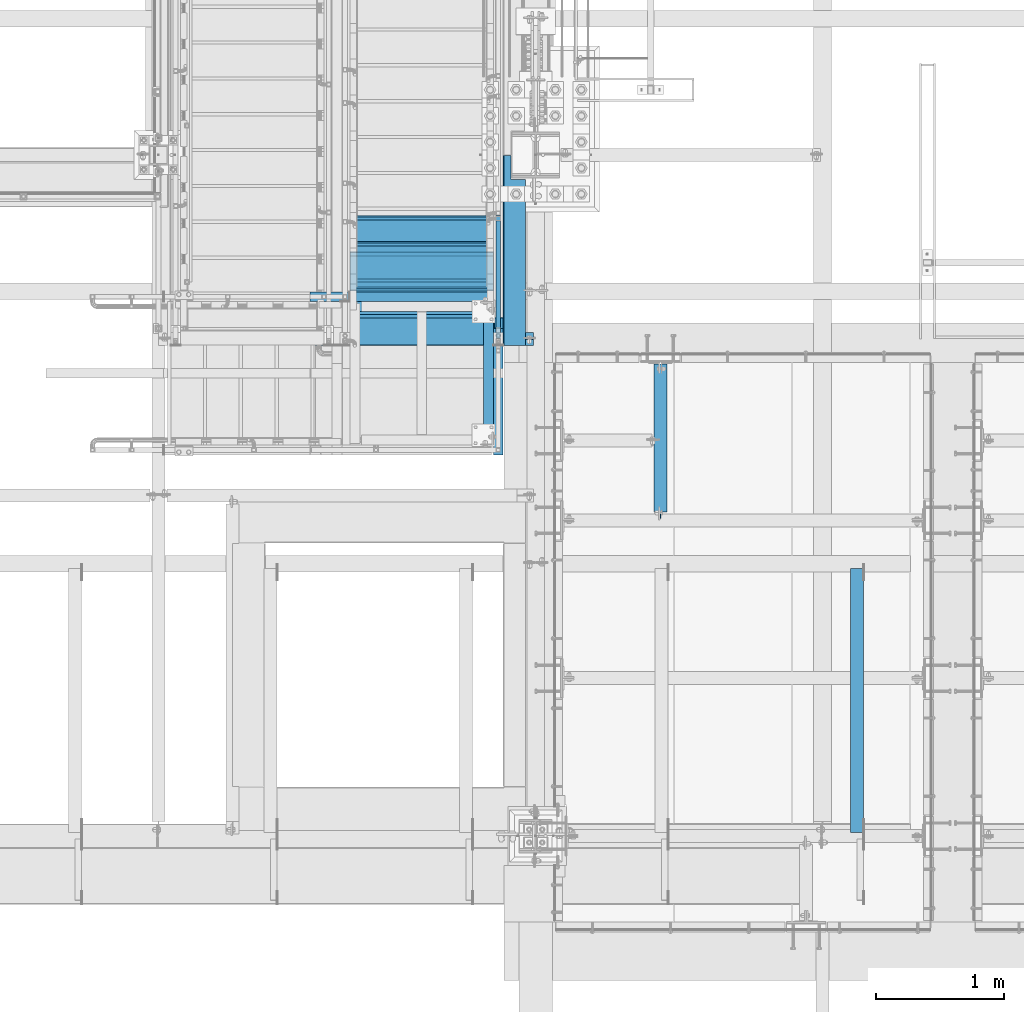
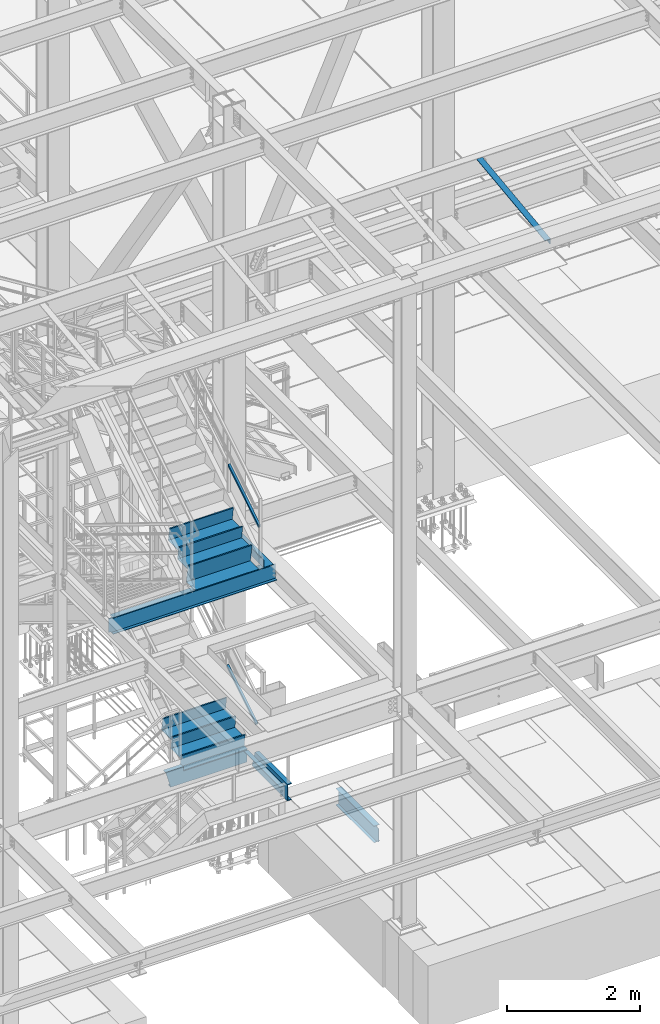
# One storey, part 1762 of 3843: 14 beams, 2 members, 9 elements without a shape of their own.
"""IFC2X3 building model written with IfcOpenShell, lengths in millimetres."""

from ifc_helpers import new_model, si_unit, frame, origin_with_axes, place, context, subcontext, project, spatial, faceted_brep, material, type_object, element, aggregate, save


model = new_model("IFC2X3")

# Units and contexts
model_context = context("Model", 3, precision=1e-05, world=origin_with_axes())
body_context = subcontext(model_context, "Body", "Model", "MODEL_VIEW")
ifc_project = project(units=[si_unit("LENGTHUNIT", "METRE", prefix="MILLI"), si_unit("AREAUNIT", "SQUARE_METRE"), si_unit("VOLUMEUNIT", "CUBIC_METRE"), si_unit("MASSUNIT", "GRAM", prefix="KILO"), si_unit("TIMEUNIT", "SECOND"), si_unit("PLANEANGLEUNIT", "RADIAN"), si_unit("SOLIDANGLEUNIT", "STERADIAN"), si_unit("THERMODYNAMICTEMPERATUREUNIT", "DEGREE_CELSIUS"), si_unit("LUMINOUSINTENSITYUNIT", "LUMEN")], contexts=[model_context])

# Site, building, storey
site_placement = place(None, origin_with_axes())
site = spatial("IfcSite", under=ifc_project, at=site_placement, CompositionType="ELEMENT")
building_placement = place(site_placement, origin_with_axes())
building = spatial("IfcBuilding", under=site, at=building_placement, Name="Undefined", CompositionType="ELEMENT")
storey_placement = place(building_placement, origin_with_axes())
storey = spatial("IfcBuildingStorey", under=building, at=storey_placement, Name="Undefined", CompositionType="ELEMENT", Elevation=0.0)

# Assembly, member
assembly_1_placement = place(storey_placement, origin_with_axes())
assembly_1 = element("IfcElementAssembly", 1, at=assembly_1_placement, inside=storey, Name="RAIL", AssemblyPlace="NOTDEFINED", PredefinedType="RIGID_FRAME")
ifc_material_1 = material()
member_type = type_object("IfcMemberType", Name="HSS1-1/2X1-1/2X1/4", PredefinedType="NOTDEFINED")
member_1_placement = place(assembly_1_placement, frame((55638.6999999992, 18859.5000000038, 35547.2230284887), z_axis=(0.0, -0.529536736899111, 0.848287005838379), x_axis=(0.0, 0.848287005838377, 0.529536736899114)))
member_1 = element("IfcMember", 2, at=member_1_placement, type_object=member_type, material=ifc_material_1, Name="RAIL", ObjectType="HSS1-1/2X1-1/2X1/4", context=body_context, shape_type="Brep", body=[
    faceted_brep([(1112.28589844752, -19.0499992350015, 19.0499992315272), (1088.50226304266, -19.0499992350015, -19.0499992383411), (1088.50226304266, 19.0499992350015, -19.0499992383411), (1112.28589844752, 19.0499992350015, 19.0499992315272), (1108.32195911351, -12.6999993299978, 12.699999326549), (1108.32195911351, 12.6999993299978, 12.699999326549), (1092.46620237669, 12.6999993299978, -12.6999993333629), (1092.46620237669, -12.6999993299978, -12.6999993333629), (34.3488397583606, 19.0499992350015, 19.0499992348923), (34.3488397583606, -19.0499999999956, 19.0499992348923), (10.5652043534537, -19.0499992350015, -19.0499992349432), (10.5652043534537, 19.0499992350015, -19.0499992349432), (30.3849004243275, -12.6999993300014, 12.6999993299178), (14.5291436874832, -12.6999993300014, -12.6999993299687), (14.5291436874832, 12.6999993300014, -12.6999993299687), (30.3849004243275, 12.6999993300014, 12.6999993299178)], [[[0, 1, 2, 3], [4, 5, 6, 7]], [[0, 3, 8, 9]], [[2, 1, 10, 11]], [[1, 0, 9, 10]], [[3, 2, 11, 8]], [[9, 8, 11, 10], [12, 13, 14, 15]], [[4, 7, 13, 12]], [[7, 6, 14, 13]], [[6, 5, 15, 14]], [[5, 4, 12, 15]]]),
])
aggregate(assembly_1, [member_1])

assembly_2_placement = place(storey_placement, origin_with_axes())
assembly_2 = element("IfcElementAssembly", 3, at=assembly_2_placement, inside=storey, Name="RAIL", AssemblyPlace="NOTDEFINED", PredefinedType="RIGID_FRAME")
member_2_placement = place(assembly_2_placement, frame((55638.7000000026, 18961.0999978671, 31873.0923071052), z_axis=(0.0, -0.524097425050603, 0.851658317082225), x_axis=(0.0, 0.851658317082228, 0.524097425050598)))
member_2 = element("IfcMember", 4, at=member_2_placement, type_object=member_type, material=ifc_material_1, Name="RAIL", ObjectType="HSS1-1/2X1-1/2X1/4", context=body_context, shape_type="Brep", body=[
    faceted_brep([(-3.59463567009516, 12.6999993300014, -12.6999993299978), (-3.59463567009516, -12.6999993300014, -12.6999993299978), (1017.39036485115, -12.6999993299978, -12.6999993288809), (1017.39036485115, 12.6999993299978, -12.6999993288809), (3.59463559381402, -12.6999993300014, 12.6999993299833), (1033.02113323208, -12.6999993299978, 12.6999993311583), (3.59463559381402, 12.6999993300014, 12.6999993299833), (1033.02113323208, 12.6999993299978, 12.6999993311583), (-5.39195355401171, 19.0499992350015, -19.0499992349942), (5.39195347770146, 19.0499992350015, 19.0499992349796), (1036.92882547501, 19.0499992350015, 19.049999236162), (1013.48267260822, 19.0499992350015, -19.0499992338882), (5.39195347770146, -19.0499992350015, 19.0499992349796), (1036.92882547501, -19.0499992350015, 19.049999236162), (-5.39195355401171, -19.0499992350015, -19.0499992349942), (1013.48267260822, -19.0499992350015, -19.0499992338882)], [[[0, 1, 2, 3]], [[1, 4, 5, 2]], [[4, 6, 7, 5]], [[6, 0, 3, 7]], [[8, 9, 10, 11]], [[9, 12, 13, 10]], [[12, 14, 15, 13]], [[14, 8, 11, 15]], [[13, 15, 11, 10], [5, 7, 3, 2]], [[14, 12, 9, 8], [6, 4, 1, 0]]]),
])
aggregate(assembly_2, [member_2])

# Assembly, beam
assembly_3_placement = place(storey_placement, origin_with_axes())
assembly_3 = element("IfcElementAssembly", 5, at=assembly_3_placement, inside=storey, Name="STAIR", AssemblyPlace="NOTDEFINED", PredefinedType="RIGID_FRAME")
ifc_material_2 = material(Name="STEEL/A36")
beam_type_1 = type_object("IfcBeamType", PredefinedType="NOTDEFINED")
beam_1_placement = place(assembly_3_placement, frame((54476.6499999817, 19202.4000000623, 31285.7173071028), z_axis=(0.0, 1.0, 0.0), x_axis=(1.0, 0.0, 0.0)))
beam_1 = element("IfcBeam", 6, at=beam_1_placement, type_object=beam_type_1, material=ifc_material_2, Name="PLATE", context=body_context, shape_type="Brep", body=[
    faceted_brep([(0.0, 3.17500000000291, -38.0999999999985), (0.0, 3.17500000000291, 38.0999999999985), (1111.25000001924, 3.17500000000291, 38.0999999999985), (1111.25000001924, 3.17500000000291, -38.0999999999985), (0.0, -3.17500000000291, 38.0999999999985), (1111.25000001924, -3.17500000000291, 38.0999999999985), (0.0, -3.17500000000291, -38.0999999999985), (1111.25000001924, -3.17500000000291, -38.0999999999985)], [[[0, 1, 2, 3]], [[1, 4, 5, 2]], [[4, 6, 7, 5]], [[6, 0, 3, 7]], [[5, 7, 3, 2]], [[6, 4, 1, 0]]]),
])

# Assembly, beams
assembly_4_placement = place(storey_placement, origin_with_axes())
assembly_4 = element("IfcElementAssembly", 7, at=assembly_4_placement, inside=storey, Name="STAIR", AssemblyPlace="NOTDEFINED", PredefinedType="RIGID_FRAME")
ifc_material_3 = material(Name="STEEL/ASTM A1011")
beam_type_2 = type_object("IfcBeamType", PredefinedType="NOTDEFINED")
beam_2_placement = place(assembly_4_placement, frame((55041.7999998292, 19824.7000000011, 31853.9201913701), z_axis=(1.0, 0.0, 0.0), x_axis=(0.0, -1.0, 0.0)))
beam_2 = element("IfcBeam", 8, at=beam_2_placement, type_object=beam_type_2, material=ifc_material_3, Name="TREAD", context=body_context, shape_type="Brep", body=[
    faceted_brep([(0.0, -1.58750000000146, -558.799999999999), (0.0, -1.58750000000146, 558.799999999999), (0.0, 1.58750000000146, 558.799999999999), (0.0, 1.58750000000146, -558.799999999999), (21.7215083258779, 1.58750000000146, 558.799999999999), (21.7215083258779, 1.58750000000146, -558.799999999999), (25.3999999999942, -1.58750000000146, -558.799999999999), (25.3999999999942, -1.58750000000146, 558.799999999999), (-11.1830371286633, 224.325961538467, 558.799999999999), (-11.1830371286633, 224.325961538467, -558.799999999999), (-7.50454545454704, 221.150961538464, -558.799999999999), (-7.50454545454704, 221.150961538464, 558.799999999999), (293.616962871325, 224.325961538467, 558.799999999999), (293.616962871325, 224.325961538467, -558.799999999999), (290.876539379024, 221.150961538464, -558.799999999999), (290.876539379024, 221.150961538464, 558.799999999999), (299.585432747743, 183.924011605752, 558.799999999999), (299.585432747743, 183.924011605752, -558.799999999999), (296.444520385252, 183.460013188564, 558.799999999999), (296.444520385252, 183.460013188564, -558.799999999999)], [[[0, 1, 2, 3]], [[3, 2, 4, 5]], [[1, 0, 6, 7]], [[5, 4, 8, 9]], [[7, 6, 10, 11]], [[9, 8, 12, 13]], [[11, 10, 14, 15]], [[13, 12, 16, 17]], [[12, 8, 4, 2, 1, 7, 11, 15, 18, 16]], [[15, 14, 19, 18]], [[14, 10, 6, 0, 3, 5, 9, 13, 17, 19]], [[18, 19, 17, 16]]]),
])
beam_3_placement = place(assembly_4_placement, frame((55041.7999998292, 19545.3000000005, 31681.98172995), z_axis=(1.0, 0.0, 0.0), x_axis=(0.0, -1.0, 0.0)))
beam_3 = element("IfcBeam", 9, at=beam_3_placement, type_object=beam_type_2, material=ifc_material_3, Name="TREAD", context=body_context, shape_type="Brep", body=[
    faceted_brep([(0.0, -1.58750000000146, -558.799999999999), (0.0, -1.58750000000146, 558.799999999999), (0.0, 1.58750000000146, 558.799999999999), (0.0, 1.58750000000146, -558.799999999999), (21.7215083258779, 1.58750000000146, 558.799999999999), (21.7215083258779, 1.58750000000146, -558.799999999999), (25.3999999999942, -1.58750000000146, -558.799999999999), (25.3999999999942, -1.58750000000146, 558.799999999999), (-11.1830371286633, 224.325961538467, 558.799999999999), (-11.1830371286633, 224.325961538467, -558.799999999999), (-7.50454545454704, 221.150961538464, -558.799999999999), (-7.50454545454704, 221.150961538464, 558.799999999999), (293.616962871325, 224.325961538467, 558.799999999999), (293.616962871325, 224.325961538467, -558.799999999999), (290.876539379024, 221.150961538464, -558.799999999999), (290.876539379024, 221.150961538464, 558.799999999999), (299.585432747743, 183.924011605752, 558.799999999999), (299.585432747743, 183.924011605752, -558.799999999999), (296.444520385252, 183.460013188564, 558.799999999999), (296.444520385252, 183.460013188564, -558.799999999999)], [[[0, 1, 2, 3]], [[3, 2, 4, 5]], [[1, 0, 6, 7]], [[5, 4, 8, 9]], [[7, 6, 10, 11]], [[9, 8, 12, 13]], [[11, 10, 14, 15]], [[13, 12, 16, 17]], [[12, 8, 4, 2, 1, 7, 11, 15, 18, 16]], [[15, 14, 19, 18]], [[14, 10, 6, 0, 3, 5, 9, 13, 17, 19]], [[18, 19, 17, 16]]]),
])
beam_type_3 = type_object("IfcBeamType", Name="C12X20.7", PredefinedType="NOTDEFINED")
beam_4_placement = place(assembly_4_placement, frame((55638.7000000001, 17970.4999999997, 31212.6923071055), z_axis=(0.0, 0.0, 1.0), x_axis=(0.0, 1.0, 0.0)))
beam_4 = element("IfcBeam", 10, at=beam_4_placement, type_object=beam_type_3, material=ifc_material_2, Name="STAIR", ObjectType="C12X20.7", context=body_context, shape_type="Brep", body=[
    faceted_brep([(0.0, 38.0999999999985, -152.400000000001), (0.0, 38.0999999999985, 152.400000000001), (983.410728369086, 38.0999999999985, 152.400000000001), (1069.68198781678, 38.0999999999985, -152.400000000001), (0.0, -38.0999999999985, 152.400000000001), (983.410728369086, -38.0999999999985, 152.400000000001), (0.0, -38.0999999999985, 146.047460000002), (985.208765201409, -38.0999999999985, 146.047460000002), (0.0, 30.1624999999985, 134.6749275), (988.427671703656, 30.1624999999985, 134.6749275), (0.0, 30.1624999999985, -134.6749275), (1064.66504448221, 30.1624999999985, -134.6749275), (0.0, -38.0999999999985, -146.047460000002), (1067.88395098446, -38.0999999999985, -146.047460000002), (0.0, -38.0999999999985, -152.400000000001), (1069.68198781678, -38.0999999999985, -152.400000000001)], [[[0, 1, 2, 3]], [[1, 4, 5, 2]], [[4, 6, 7, 5]], [[6, 8, 9, 7]], [[8, 10, 11, 9]], [[10, 12, 13, 11]], [[12, 14, 15, 13]], [[14, 0, 3, 15]], [[5, 7, 9, 11, 13, 15, 3, 2]], [[14, 12, 10, 8, 6, 4, 1, 0]]]),
])

# Beam
beam_5_placement = place(assembly_3_placement, frame((55600.5999999746, 19202.400000064, 31212.6923070538), z_axis=(0.0, 0.0, 1.0), x_axis=(-1.0, 0.0, 0.0)))
beam_5 = element("IfcBeam", 11, at=beam_5_placement, type_object=beam_type_3, material=ifc_material_2, Name="STAIR", ObjectType="C12X20.7", context=body_context, shape_type="Brep", body=[
    faceted_brep([(1123.94999999381, 30.1624999999985, 69.8500000488821), (1123.94999999381, 38.0999999999985, 69.8500000488821), (12.6999999744803, 38.0999999999985, 69.8500000488748), (12.6999999744803, 30.1624999999985, 69.8500000488748), (1123.94999999373, -38.0999999999985, 152.400000010261), (1123.94999999373, 38.0999999999985, 152.400000000001), (1123.94999999374, 30.1624999999985, 134.6749275), (1123.94999999373, -38.0999999999985, 146.047460000002), (1345.11604899714, -38.0999999999985, -146.047460000002), (1348.33495549939, 30.1624999999985, -134.6749275), (12.7000000007174, 30.1624999999985, -134.674927499997), (12.7000000007174, -38.0999999999985, -146.047460000002), (1343.31801216482, -38.0999999999985, -152.400000000001), (12.7000000007174, -38.0999999999985, -152.400000000001), (1343.31801216482, 38.0999999999985, -152.400000000001), (12.7000000007174, 38.0999999999985, -152.400000000001), (1429.58927161252, -38.0999999999985, 152.400000000001), (1427.79123478019, -38.0999999999985, 146.047460000002), (1424.57232827794, 30.1624999999985, 134.6749275), (1429.58927161252, 38.0999999999985, 152.400000000001)], [[[0, 1, 2, 3]], [[4, 5, 1, 0, 6, 7]], [[8, 9, 10, 11]], [[12, 8, 11, 13]], [[14, 12, 13, 15]], [[16, 17, 18, 9, 8, 12, 14, 19]], [[17, 16, 4, 7]], [[18, 17, 7, 6]], [[3, 10, 9, 18, 6, 0]], [[15, 13, 11, 10, 3, 2]], [[19, 14, 15, 2, 1, 5]], [[16, 19, 5, 4]]]),
])

aggregate(assembly_3, [beam_1, beam_5])

# Assembly, beam
assembly_5_placement = place(storey_placement, origin_with_axes())
assembly_5 = element("IfcElementAssembly", 12, at=assembly_5_placement, inside=storey, Name="ANGLE", AssemblyPlace="NOTDEFINED", PredefinedType="RIGID_FRAME")
ifc_material_4 = material(Name="STEEL/A572-50")
beam_type_4 = type_object("IfcBeamType", Name="L4X4X3/8", PredefinedType="NOTDEFINED")
beam_6_placement = place(assembly_5_placement, frame((58434.2875, 17090.2662426835, 42392.9829998706), z_axis=(-1.0, 0.0, 0.0), x_axis=(0.0, -0.99246063250399, -0.122563832062241)))
beam_6 = element("IfcBeam", 13, at=beam_6_placement, type_object=beam_type_4, material=ifc_material_4, Name="ANGLE", ObjectType="L4X4X3/8", context=body_context, shape_type="Brep", body=[
    faceted_brep([(0.0, 50.8000000000029, -50.8000000000029), (0.0, 50.8000000000029, 50.8000000000029), (2072.3895061554, 50.8000000024476, 50.8000000000029), (2072.3895061554, 50.8000000024476, -50.8000000000029), (0.0, 41.2750000000015, 50.8000000000029), (2072.38950615541, 41.2750000024098, 50.8000000000029), (0.0, 41.2749999999942, -41.2750000000015), (2072.38950615541, 41.2750000024098, -41.2750000000015), (0.0, -50.8000000000029, -41.2750000000015), (2072.38950615556, -50.7999999979074, -41.2750000000015), (0.0, -50.8000000000029, -50.8000000000029), (2072.38950615556, -50.7999999979074, -50.8000000000029)], [[[0, 1, 2, 3]], [[1, 4, 5, 2]], [[4, 6, 7, 5]], [[6, 8, 9, 7]], [[8, 10, 11, 9]], [[10, 0, 3, 11]], [[5, 7, 9, 11, 3, 2]], [[10, 8, 6, 4, 1, 0]]]),
])
aggregate(assembly_5, [beam_6])

# Beam
beam_type_5 = type_object("IfcBeamType", Name="L3X3X1/4", PredefinedType="NOTDEFINED")
beam_7_placement = place(assembly_4_placement, frame((55562.5, 19151.6000000637, 31250.7923071195), z_axis=(-1.0, 0.0, 0.0), x_axis=(0.0, -1.0, 0.0)))
beam_7 = element("IfcBeam", 14, at=beam_7_placement, type_object=beam_type_5, material=ifc_material_2, Name="ANGLE", ObjectType="L3X3X1/4", context=body_context, shape_type="Brep", body=[
    faceted_brep([(990.600000450311, -38.0999999999985, -31.75), (990.600000450311, -38.0999999999985, -38.1000000000058), (990.599999999697, 31.7500000058135, -38.0999999999985), (990.600000450311, 31.75, -31.75), (1092.20000022113, 31.75, -31.75), (1092.20000022113, 31.7499999999927, -38.0999999999985), (101.600000050574, 31.75, -31.75), (101.60000008007, -38.0999999938067, -31.75), (101.60000008007, -38.0999999999985, -38.0999999999985), (0.0, 38.0999999999985, -38.0999999999985), (0.0, 38.0999999999985, 38.0999999999985), (1092.20000022635, 38.0999999990308, 38.0999999999985), (1092.20000022635, 38.0999999990308, -38.0999999999985), (101.600000050574, 31.7499999828287, -38.0999999999985), (0.0, 31.7500000838336, -38.0999999999985), (0.0, 31.75, -31.75), (0.0, 31.75, 38.0999999999985), (101.600000050574, 31.75, 38.0999999999985), (990.600000450311, 31.75, 38.1000000000058), (1092.19999991878, 31.75, 38.0999999999985)], [[[0, 1, 2, 3]], [[4, 3, 2, 5]], [[6, 7, 0, 3]], [[7, 8, 1, 0]], [[9, 10, 11, 12]], [[1, 8, 13, 14, 9, 12, 5, 2]], [[7, 6, 13, 8]], [[15, 14, 13, 6]], [[16, 10, 9, 14, 15]], [[10, 16, 17, 18, 19, 11]], [[12, 11, 19, 4, 5]], [[18, 17, 16, 15, 6, 3, 4, 19]]]),
])

# Assembly, beams
assembly_6_placement = place(storey_placement, origin_with_axes())
assembly_6 = element("IfcElementAssembly", 15, at=assembly_6_placement, inside=storey, Name="STAIR", AssemblyPlace="NOTDEFINED", PredefinedType="RIGID_FRAME")
beam_type_6 = type_object("IfcBeamType", PredefinedType="NOTDEFINED")
beam_8_placement = place(assembly_6_placement, frame((55041.8000001424, 19621.5000000018, 35472.0524972689), z_axis=(1.0, 0.0, 0.0), x_axis=(0.0, -1.0, 0.0)))
beam_8 = element("IfcBeam", 16, at=beam_8_placement, type_object=beam_type_6, material=ifc_material_3, Name="TREAD", context=body_context, shape_type="Brep", body=[
    faceted_brep([(0.0, -1.58750000000146, -558.799999999999), (0.0, -1.58750000000146, 558.799999999999), (0.0, 1.58750000000146, 558.799999999999), (0.0, 1.58750000000146, -558.799999999999), (21.7291296566655, 1.58749999984138, 558.800000000003), (21.7291296566655, 1.58749999984138, -558.800000000003), (25.3999999999942, -1.58750000000146, -558.799999999999), (25.3999999999942, -1.58750000000146, 558.799999999999), (-11.0689285898225, 226.800833434812, 558.800000000003), (-11.0689285898225, 226.800833434812, -558.800000000003), (-7.39805824649738, 223.625833434788, -558.800000000003), (-7.39805824649738, 223.625833434788, 558.800000000003), (293.731071409333, 226.8008334326, 558.800000000003), (293.731071409333, 226.8008334326, -558.800000000003), (290.984958346977, 223.625833432619, -558.800000000003), (290.984958346977, 223.625833432619, 558.800000000003), (299.617441696697, 186.381090767136, 558.800000000003), (299.617441696697, 186.381090767136, -558.800000000003), (296.47558379783, 185.923538646231, 558.800000000003), (296.47558379783, 185.923538646231, -558.800000000003)], [[[0, 1, 2, 3]], [[3, 2, 4, 5]], [[1, 0, 6, 7]], [[5, 4, 8, 9]], [[7, 6, 10, 11]], [[9, 8, 12, 13]], [[11, 10, 14, 15]], [[13, 12, 16, 17]], [[12, 8, 4, 2, 1, 7, 11, 15, 18, 16]], [[15, 14, 19, 18]], [[14, 10, 6, 0, 3, 5, 9, 13, 17, 19]], [[18, 19, 17, 16]]]),
])
beam_9_placement = place(assembly_6_placement, frame((55041.8000001424, 19342.1000000013, 35297.6391638362), z_axis=(1.0, 0.0, 0.0), x_axis=(0.0, -1.0, 0.0)))
beam_9 = element("IfcBeam", 17, at=beam_9_placement, type_object=beam_type_6, material=ifc_material_3, Name="TREAD", context=body_context, shape_type="Brep", body=[
    faceted_brep([(0.0, -1.58750000000146, -558.799999999999), (0.0, -1.58750000000146, 558.799999999999), (0.0, 1.58750000000146, 558.799999999999), (0.0, 1.58750000000146, -558.799999999999), (21.7291296566655, 1.58749999984138, 558.800000000003), (21.7291296566655, 1.58749999984138, -558.800000000003), (25.3999999999942, -1.58750000000146, -558.799999999999), (25.3999999999942, -1.58750000000146, 558.799999999999), (-11.0689285898225, 226.800833434812, 558.800000000003), (-11.0689285898225, 226.800833434812, -558.800000000003), (-7.39805824649738, 223.625833434788, -558.800000000003), (-7.39805824649738, 223.625833434788, 558.800000000003), (293.731071409333, 226.8008334326, 558.800000000003), (293.731071409333, 226.8008334326, -558.800000000003), (290.984958346977, 223.625833432619, -558.800000000003), (290.984958346977, 223.625833432619, 558.800000000003), (299.617441696697, 186.381090767136, 558.800000000003), (299.617441696697, 186.381090767136, -558.800000000003), (296.47558379783, 185.923538646231, 558.800000000003), (296.47558379783, 185.923538646231, -558.800000000003)], [[[0, 1, 2, 3]], [[3, 2, 4, 5]], [[1, 0, 6, 7]], [[5, 4, 8, 9]], [[7, 6, 10, 11]], [[9, 8, 12, 13]], [[11, 10, 14, 15]], [[13, 12, 16, 17]], [[12, 8, 4, 2, 1, 7, 11, 15, 18, 16]], [[15, 14, 19, 18]], [[14, 10, 6, 0, 3, 5, 9, 13, 17, 19]], [[18, 19, 17, 16]]]),
])

# Assembly, beam
assembly_7_placement = place(storey_placement, origin_with_axes())
assembly_7 = element("IfcElementAssembly", 18, at=assembly_7_placement, inside=storey, Name="BEAM", AssemblyPlace="NOTDEFINED", PredefinedType="RIGID_FRAME")
ifc_material_5 = material(Name="STEEL/A992")
beam_type_7 = type_object("IfcBeamType", Name="W12X19", PredefinedType="NOTDEFINED")
beam_10_placement = place(assembly_7_placement, frame((52990.75, 18872.2, 34656.7125), z_axis=(0.0, 0.0, 1.0), x_axis=(1.0, 0.0, 0.0)))
beam_10 = element("IfcBeam", 19, at=beam_10_placement, type_object=beam_type_7, material=ifc_material_5, Name="BEAM", ObjectType="W12X19", context=body_context, shape_type="Brep", body=[
    faceted_brep([(15.8750000000146, -3.17500000000291, -128.587499998961), (15.8750000000146, 3.17500000000291, -128.587499998961), (53.9750001907523, 3.17500000000291, -128.587499998961), (53.9750001907523, -3.17500000000291, -128.587499998961), (58.8350797087915, 3.17500000000291, -129.554229921552), (58.8350797087915, -3.17500000000291, -129.554229921552), (62.9552561769524, 3.17500000000291, -132.307243822026), (62.9552561769524, -3.17500000000291, -132.307243822026), (65.7082700774336, 3.17500000000291, -136.42742029018), (65.7082700774336, -3.17500000000291, -136.42742029018), (66.6750000000175, -3.17500000000291, -141.287499808226), (66.6750000000175, 3.17500000000291, -141.287499808226), (66.6750000000175, 3.17500000000291, -144.462500000001), (66.6750000000175, 50.8000000000029, -144.462500000001), (66.6750000000175, 50.8000000000029, -153.987500000003), (66.6750000000175, -50.8000000000029, -153.987500000003), (66.6750000000175, -50.8000000000029, -144.462500000001), (66.6750000000175, -3.17500000000291, -144.462500000001), (2794.79375, 50.7999999999993, 144.462500000001), (2794.79375, 3.17499999999927, 144.462500000001), (66.6750000000175, 3.17500000000291, 144.462500000001), (66.6750000000175, 50.8000000000029, 144.462500000001), (53.9750001907523, -3.17500000000291, 128.587500001042), (53.9750001907523, 3.17500000000291, 128.587500001042), (15.8750000000146, 3.17500000000291, 128.587500001042), (15.8750000000146, -3.17500000000291, 128.587500001042), (58.8350797087915, -3.17500000000291, 129.554229923633), (58.8350797087915, 3.17500000000291, 129.554229923633), (62.9552561769524, -3.17500000000291, 132.307243824107), (62.9552561769524, 3.17500000000291, 132.307243824107), (65.7082700774336, -3.17500000000291, 136.427420292261), (65.7082700774336, 3.17500000000291, 136.427420292261), (66.6750000000175, -3.17500000000291, 141.287499810307), (66.6750000000175, 3.17500000000291, 141.287499810307), (2794.79375, -50.7999999999993, 153.987500000003), (2794.79375, 50.7999999999993, 153.987500000003), (66.6750000000175, 50.8000000000029, 153.987500000003), (66.6750000000175, -50.8000000000029, 153.987500000003), (2794.79375, -50.7999999999993, 144.462500000001), (66.6750000000175, -50.8000000000029, 144.462500000001), (2794.79375, -3.17499999999927, 144.462500000001), (66.6750000000175, -3.17500000000291, 144.462500000001), (2794.79375, -3.17499999999927, 134.937499809275), (2794.79375, 3.17499999999927, 134.937499809275), (2795.7604799226, -3.17499999999927, 130.077420291229), (2795.7604799226, 3.17499999999927, 130.077420291229), (2798.51349382307, -3.17499999999927, 125.957243823075), (2798.51349382307, 3.17499999999927, 125.957243823075), (2802.63367029122, -3.17499999999927, 123.204229922601), (2802.63367029122, 3.17499999999927, 123.204229922601), (2807.49374980927, -3.17499999999927, 122.23750000001), (2807.49374980927, 3.17499999999927, 122.23750000001), (2921.79375, -3.17499999999927, 122.23750000001), (2921.79375, 3.17499999999927, 122.23750000001), (2921.79375, -3.17499999999927, -144.462500000001), (2921.79375, -50.7999999999993, -144.462500000001), (2921.79375, -50.7999999999993, -153.987500000003), (2921.79375, 50.7999999999993, -153.987500000003), (2921.79375, 50.7999999999993, -144.462500000001), (2921.79375, 3.17499999999927, -144.462500000001), (2921.79375, 3.17499999999927, -114.712500000001), (2921.79375, 3.17499999999927, 115.887499999997), (15.8750000000146, 3.17500000000291, -114.712499998386), (15.8750000000146, 3.17500000000291, 115.887500001612)], [[[0, 1, 2, 3]], [[3, 2, 4, 5]], [[5, 4, 6, 7]], [[7, 6, 8, 9]], [[10, 11, 12, 13, 14, 15, 16, 17]], [[9, 8, 11, 10]], [[18, 19, 20, 21]], [[22, 23, 24, 25]], [[26, 27, 23, 22]], [[28, 29, 27, 26]], [[30, 31, 29, 28]], [[32, 33, 31, 30]], [[34, 35, 36, 37]], [[38, 34, 37, 39]], [[40, 38, 39, 41]], [[37, 36, 21, 20, 33, 32, 41, 39]], [[35, 18, 21, 36]], [[34, 38, 40, 42, 43, 19, 18, 35]], [[44, 45, 43, 42]], [[46, 47, 45, 44]], [[48, 49, 47, 46]], [[50, 51, 49, 48]], [[52, 53, 51, 50]], [[54, 55, 56, 57, 58, 59, 60, 61, 53, 52]], [[55, 54, 17, 16]], [[56, 55, 16, 15]], [[57, 56, 15, 14]], [[58, 57, 14, 13]], [[59, 58, 13, 12]], [[6, 4, 2, 1, 62, 63, 24, 23, 27, 29, 31, 33, 20, 19, 43, 45, 47, 49, 51, 53, 61, 60, 59, 12, 11, 8]], [[25, 24, 63, 62, 1, 0]], [[54, 52, 50, 48, 46, 44, 42, 40, 41, 32, 30, 28, 26, 22, 25, 0, 3, 5, 7, 9, 10, 17]]]),
])
aggregate(assembly_7, [beam_10])

# Beam
beam_type_8 = type_object("IfcBeamType", PredefinedType="NOTDEFINED")
beam_11_placement = place(assembly_6_placement, frame((55041.8000001424, 19062.7000000009, 35123.2258304035), z_axis=(1.0, 0.0, 0.0), x_axis=(0.0, -1.0, 0.0)))
beam_11 = element("IfcBeam", 20, at=beam_11_placement, type_object=beam_type_8, material=ifc_material_3, Name="TREAD", context=body_context, shape_type="Brep", body=[
    faceted_brep([(0.0, -1.58750000000146, -558.799999999999), (0.0, -1.58750000000146, 558.799999999999), (0.0, 1.58750000000146, 558.799999999999), (0.0, 1.58750000000146, -558.799999999999), (21.723724725638, 1.58750000000146, 558.800000000003), (21.723724725638, 1.58750000000146, -558.800000000003), (25.3999999999942, -1.58750000000146, -558.799999999999), (25.3999999999942, -1.58750000000146, 558.799999999999), (-24.0228674807768, 312.539100000002, 558.800000000003), (-24.0228674807768, 312.539100000002, -558.800000000003), (-20.3465922064242, 309.364099999999, -558.800000000003), (-20.3465922064242, 309.364099999999, 558.800000000003), (234.950000000001, 312.539100000002, 558.800000000003), (234.950000000001, 312.539100000002, -558.800000000003), (234.950000000001, 309.364099999999, 558.800000000003), (234.950000000001, 309.364099999999, -558.800000000003)], [[[0, 1, 2, 3]], [[3, 2, 4, 5]], [[1, 0, 6, 7]], [[5, 4, 8, 9]], [[7, 6, 10, 11]], [[9, 8, 12, 13]], [[8, 4, 2, 1, 7, 11, 14, 12]], [[11, 10, 15, 14]], [[10, 6, 0, 3, 5, 9, 13, 15]], [[14, 15, 13, 12]]]),
])

aggregate(assembly_6, [beam_8, beam_9, beam_11])

beam_type_9 = type_object("IfcBeamType", PredefinedType="NOTDEFINED")
beam_12_placement = place(assembly_4_placement, frame((55041.7999998292, 19265.8999999998, 31510.04326853), z_axis=(1.0, 0.0, 0.0), x_axis=(0.0, -1.0, 0.0)))
beam_12 = element("IfcBeam", 21, at=beam_12_placement, type_object=beam_type_9, material=ifc_material_3, Name="TREAD", context=body_context, shape_type="Brep", body=[
    faceted_brep([(0.0, -1.58750000000146, -558.799999999999), (0.0, -1.58750000000146, 558.799999999999), (0.0, 1.58750000000146, 558.799999999999), (0.0, 1.58750000000146, -558.799999999999), (21.7137243932593, 1.58749999992142, 558.800000000003), (21.7137243932593, 1.58749999992142, -558.800000000003), (25.3999999999942, -1.58750000000146, -558.799999999999), (25.3999999999942, -1.58750000000146, 558.799999999999), (-11.1772949465776, 221.059400000042, 558.800000000003), (-11.1772949465776, 221.059400000042, -558.800000000003), (-7.49101933983911, 217.884400000028, -558.800000000003), (-7.49101933983911, 217.884400000028, 558.800000000003), (95.2500000008149, 221.059399999656, 558.800000000003), (95.2500000008149, 221.059399999656, -558.800000000003), (95.2500000008004, 217.884399999653, 558.800000000003), (95.2500000008004, 217.884399999653, -558.800000000003)], [[[0, 1, 2, 3]], [[3, 2, 4, 5]], [[1, 0, 6, 7]], [[5, 4, 8, 9]], [[7, 6, 10, 11]], [[9, 8, 12, 13]], [[8, 4, 2, 1, 7, 11, 14, 12]], [[11, 10, 15, 14]], [[10, 6, 0, 3, 5, 9, 13, 15]], [[14, 15, 13, 12]]]),
])

aggregate(assembly_4, [beam_7, beam_4, beam_2, beam_3, beam_12])

# Assembly, beam
assembly_8_placement = place(storey_placement, origin_with_axes())
assembly_8 = element("IfcElementAssembly", 22, at=assembly_8_placement, inside=storey, AssemblyPlace="NOTDEFINED", PredefinedType="RIGID_FRAME")
beam_type_10 = type_object("IfcBeamType", PredefinedType="NOTDEFINED")
beam_13_placement = place(assembly_8_placement, frame((55851.425, 19562.7317309656, 34813.875), z_axis=(0.0, -1.0, 0.0), x_axis=(-1.0, 0.0, 0.0)))
beam_13 = element("IfcBeam", 23, at=beam_13_placement, type_object=beam_type_10, material=ifc_material_2, context=body_context, shape_type="Brep", body=[
    faceted_brep([(112.712501525879, -3.17500000000291, -552.48076951953), (112.712501525879, 3.17500000000291, -552.48076951953), (112.712501525879, 3.17500000000291, -741.362499999999), (112.712501525879, -3.17500000000291, -741.362499999999), (0.0, -3.17500000000291, -552.48076951953), (0.0, 3.17500000000291, -552.48076951953), (174.625, 3.17500000000291, 741.362499999999), (0.0, 3.17500000000291, 741.362499999999), (0.0, -3.17500000000291, 741.362499999999), (168.274999999994, -3.17500000000291, 741.362499999999), (168.274999999994, -136.524996948239, 741.362499999999), (174.625, -136.524996948239, 741.362499999999), (174.625, 3.17500000000291, -741.362499999999), (174.625, -136.524996948239, -741.362499999999), (168.274999999994, -136.524996948239, -741.362499999999), (168.274999999994, -3.17500000000291, -741.362499999999)], [[[0, 1, 2, 3]], [[4, 5, 1, 0]], [[6, 7, 8, 9, 10, 11]], [[12, 6, 11, 13]], [[10, 14, 13, 11]], [[9, 15, 14, 10]], [[12, 13, 14, 15, 3, 2]], [[7, 6, 12, 2, 1, 5]], [[8, 7, 5, 4]], [[15, 9, 8, 4, 0, 3]]]),
])
aggregate(assembly_8, [beam_13])

assembly_9_placement = place(storey_placement, origin_with_axes())
assembly_9 = element("IfcElementAssembly", 24, at=assembly_9_placement, inside=storey, Name="BEAM", AssemblyPlace="NOTDEFINED", PredefinedType="RIGID_FRAME")
beam_type_11 = type_object("IfcBeamType", Name="W12X16", PredefinedType="NOTDEFINED")
beam_14_placement = place(assembly_9_placement, frame((56902.35, 17459.325, 30276.8), z_axis=(0.0, 0.0, 1.0), x_axis=(0.0, 1.0, 0.0)))
beam_14 = element("IfcBeam", 25, at=beam_14_placement, type_object=beam_type_11, material=ifc_material_5, Name="BEAM", ObjectType="W12X16", context=body_context, shape_type="Brep", body=[
    faceted_brep([(15.875, -3.17500000000291, -127.0), (15.875, 3.17500000000291, -127.0), (53.9750001907341, 3.17500000000291, -127.0), (53.9750001907341, -3.17500000000291, -127.0), (58.8350797087805, 3.17500000000291, -127.966729922588), (58.8350797087805, -3.17500000000291, -127.966729922588), (62.9552561769342, 3.17500000000291, -130.719743823065), (62.9552561769342, -3.17500000000291, -130.719743823065), (65.7082700774117, 3.17500000000291, -134.839920291219), (65.7082700774117, -3.17500000000291, -134.839920291219), (66.6749999999993, -3.17500000000291, -139.699999809265), (66.6749999999993, 3.17500000000291, -139.699999809265), (66.6749999999993, 3.17500000000291, -146.049999999999), (66.6749999999993, 50.8000000000029, -146.049999999999), (66.6749999999993, 50.8000000000029, -152.400000000001), (66.6749999999993, -50.8000000000029, -152.400000000001), (66.6749999999993, -50.8000000000029, -146.049999999999), (66.6749999999993, -3.17500000000291, -146.049999999999), (1219.19999694822, -50.8000000000029, 146.049999999999), (1219.19999694822, -50.8000000000029, 152.400000000001), (66.6749999999993, -50.8000000000029, 152.400000000001), (66.6749999999993, -50.8000000000029, 146.049999999999), (1219.19999694822, 50.8000000000029, 152.400000000001), (66.6749999999993, 50.8000000000029, 152.400000000001), (1219.19999694822, 50.8000000000029, 146.049999999999), (66.6749999999993, 50.8000000000029, 146.049999999999), (1219.19999694822, 3.17500000000291, 146.049999999999), (66.6749999999993, 3.17500000000291, 146.049999999999), (53.9750001907341, -3.17500000000291, 127.0), (53.9750001907341, 3.17500000000291, 127.0), (15.875, 3.17500000000291, 127.0), (15.875, -3.17500000000291, 127.0), (58.8350797087805, -3.17500000000291, 127.966729922588), (58.8350797087805, 3.17500000000291, 127.966729922588), (62.9552561769342, -3.17500000000291, 130.719743823065), (62.9552561769342, 3.17500000000291, 130.719743823065), (65.7082700774117, -3.17500000000291, 134.839920291219), (65.7082700774117, 3.17500000000291, 134.839920291219), (66.6749999999993, -3.17500000000291, 139.699999809265), (66.6749999999993, 3.17500000000291, 139.699999809265), (66.6749999999993, -3.17500000000291, 146.049999999999), (1219.19999694822, -3.17500000000291, 146.049999999999), (1219.19999694822, 3.17500000000291, -146.049999999999), (1219.19999694822, -3.17500000000291, -146.049999999999), (1219.19999694822, -50.8000000000029, -146.049999999999), (1219.19999694822, -50.8000000000029, -152.400000000001), (1219.19999694822, 50.8000000000029, -152.400000000001), (1219.19999694822, 50.8000000000029, -146.049999999999), (15.875, 3.17500000000291, -116.299999999999), (15.875, 3.17500000000291, 114.299999999999)], [[[0, 1, 2, 3]], [[3, 2, 4, 5]], [[5, 4, 6, 7]], [[7, 6, 8, 9]], [[10, 11, 12, 13, 14, 15, 16, 17]], [[9, 8, 11, 10]], [[18, 19, 20, 21]], [[19, 22, 23, 20]], [[22, 24, 25, 23]], [[24, 26, 27, 25]], [[28, 29, 30, 31]], [[32, 33, 29, 28]], [[34, 35, 33, 32]], [[36, 37, 35, 34]], [[38, 39, 37, 36]], [[20, 23, 25, 27, 39, 38, 40, 21]], [[41, 18, 21, 40]], [[42, 26, 24, 22, 19, 18, 41, 43, 44, 45, 46, 47]], [[44, 43, 17, 16]], [[45, 44, 16, 15]], [[46, 45, 15, 14]], [[47, 46, 14, 13]], [[42, 47, 13, 12]], [[6, 4, 2, 1, 48, 49, 30, 29, 33, 35, 37, 39, 27, 26, 42, 12, 11, 8]], [[31, 30, 49, 48, 1, 0]], [[43, 41, 40, 38, 36, 34, 32, 28, 31, 0, 3, 5, 7, 9, 10, 17]]]),
])
aggregate(assembly_9, [beam_14])

save(model, "model.ifc")
